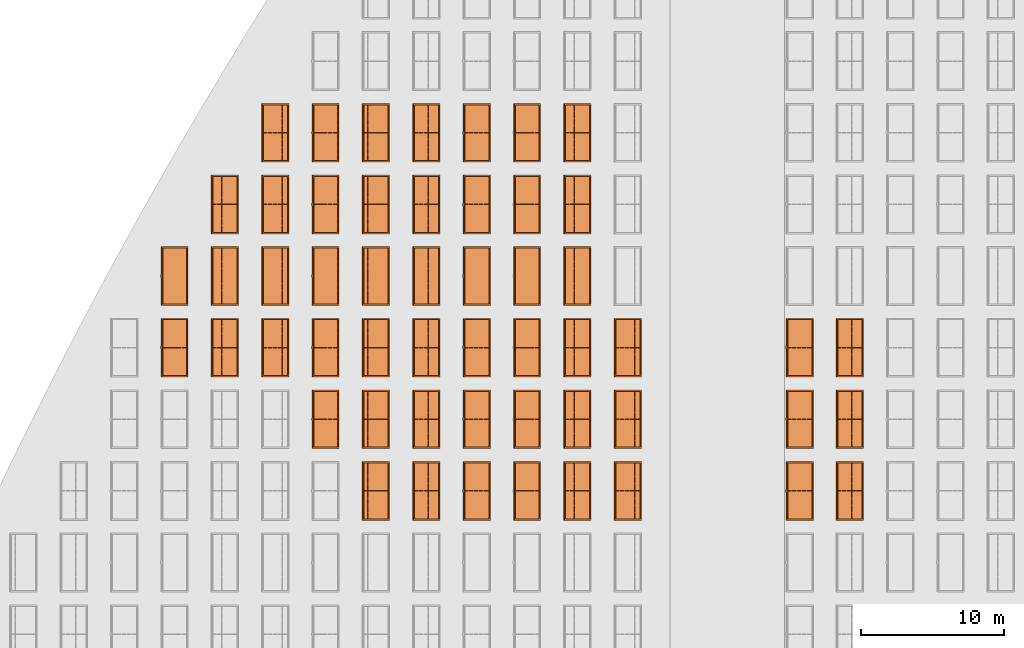
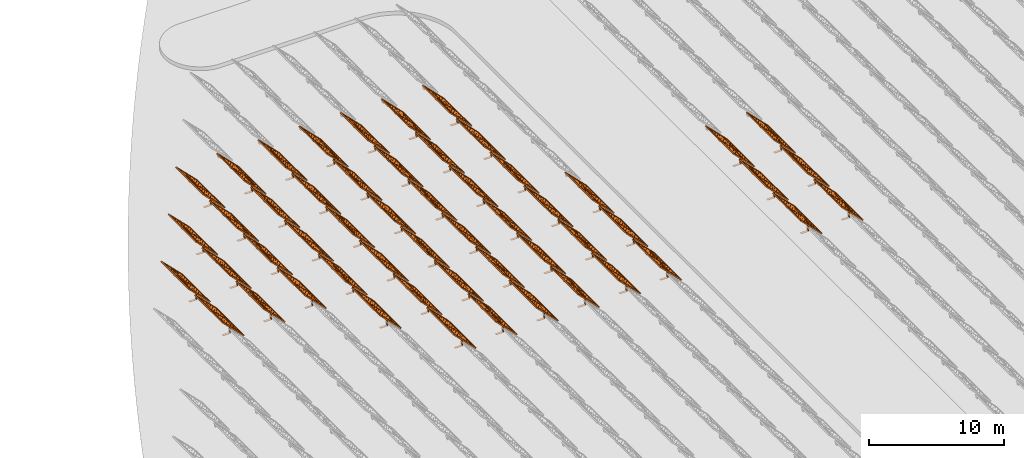
# One storey, part 29 of 39: 53 proxies.
"""IFC2X3 building model written with IfcOpenShell, lengths in millimetres."""

from ifc_helpers import new_model, entity, si_unit, converted_unit, derived_unit, direction, frame, frame_2d, origin, origin_2d_with_axis, place, context, subcontext, project, spatial, polyline, rectangle, outline, extrude, source, transform, mapped, material, material_list, element, save


model = new_model("IFC2X3")

# Units and contexts
model_context = context("Model", 3, precision=1e-06, world=origin(), true_north=direction((2.0, 6.12303176911189e-17, 1.0)))
context_of_model = context(None, 3, precision=1e-06, world=origin(), true_north=direction((2.0, 6.12303176911189e-17, 1.0)))
body_context = subcontext(model_context, "Body", "Model", "MODEL_VIEW")
ifc_project = project(units=[si_unit("LENGTHUNIT", "METRE", prefix="MILLI"), si_unit("AREAUNIT", "SQUARE_METRE", prefix="MILLI"), si_unit("VOLUMEUNIT", "CUBIC_METRE", prefix="MILLI"), converted_unit("PLANEANGLEUNIT", "DEGREE", entity("IfcRatioMeasure", 0.0174532925199433), si_unit("PLANEANGLEUNIT", "RADIAN"), dimensions=[0, 0, 0, 0, 0, 0, 0]), si_unit("MASSUNIT", "GRAM", prefix="KILO"), si_unit("TIMEUNIT", "SECOND"), si_unit("THERMODYNAMICTEMPERATUREUNIT", "KELVIN"), derived_unit("THERMALTRANSMITTANCEUNIT", [(si_unit("MASSUNIT", "GRAM", prefix="KILO"), 1), (si_unit("THERMODYNAMICTEMPERATUREUNIT", "KELVIN"), -1), (si_unit("TIMEUNIT", "SECOND"), -3)]), derived_unit("VOLUMETRICFLOWRATEUNIT", [(si_unit("LENGTHUNIT", "METRE"), 3), (si_unit("TIMEUNIT", "SECOND"), -1)])], contexts=[model_context, context_of_model])

# Site, building, storey
site_placement = place(None, origin())
site = spatial("IfcSite", under=ifc_project, at=site_placement, CompositionType="ELEMENT")
building_placement = place(site_placement, origin())
building = spatial("IfcBuilding", under=site, at=building_placement, CompositionType="ELEMENT")
storey_placement = place(building_placement, frame((0.0, 0.0, 4000.0)))
storey = spatial("IfcBuildingStorey", under=building, at=storey_placement, Name="Level 2", CompositionType="ELEMENT", Elevation=4000.0)

# Proxies
ifc_material_1 = material(Name="Stand-Steel")
ifc_material_2 = material(Name="Aluminium")
ifc_material_3 = material(Name="Glass")
ifc_material_list_1 = material_list([ifc_material_1, ifc_material_2, ifc_material_3])
shared_shape = source(origin(), body_context, "Body", "SweptSolid", [
    extrude(outline(polyline([(-629.526235435404, -220.0), (329.763117717702, -220.0), (329.763117717703, 410.0), (299.763117717703, 410.0), (299.763117717702, -190.0), (-629.526235435404, -190.0), (-629.526235435404, -220.0)])), frame((-190.00003127179, -100.0, 299.763117717707), z_axis=(0.0, 1.0, 0.0), x_axis=(0.0, 0.0, -1.0)), (0.0, 0.0, 1.0), 200.0),
    extrude(rectangle(XDim=20.0000000000001, YDim=200.0, at=frame_2d((0.0, -7.105427357601e-14), x_axis=(0.0, 1.0))), frame((-7.07109908365613, 0.0, 922.21828534124), z_axis=(-0.70710678118654, 0.0, 0.707106781186555), x_axis=(0.0, 1.0, 0.0)), (0.0, 0.0, 1.0), 2600.0),
    extrude(rectangle(XDim=24.9999999999997, YDim=24.9999999999999, at=frame_2d((2.87769807982841e-13, -9.50350909079134e-14), x_axis=(1.0, 0.0))), frame((-1449.56292018118, -1950.0, 2449.57494522722), z_axis=(0.0, 1.0, 0.0), x_axis=(-0.707106781186548, 0.0, -0.707106781186548)), (0.0, 0.0, 1.0), 3900.0),
    extrude(rectangle(XDim=24.9999999999999, YDim=25.0000000000001, at=origin_2d_with_axis()), frame((-1096.0095295879, -1950.0, 2096.02155463395), z_axis=(0.0, 1.0, 0.0), x_axis=(-0.707106781186542, 0.0, -0.707106781186553)), (0.0, 0.0, 1.0), 3900.0),
    extrude(rectangle(XDim=24.9999999999999, YDim=25.0000000000001, at=origin_2d_with_axis()), frame((-742.456138994631, -1950.0, 1742.46816404067), z_axis=(0.0, 1.0, 0.0), x_axis=(-0.707106781186542, 0.0, -0.707106781186553)), (0.0, 0.0, 1.0), 3900.0),
    extrude(rectangle(XDim=25.0, YDim=24.9999999999997, at=frame_2d((-7.19424519957101e-14, 1.19904086659517e-13), x_axis=(1.0, 0.0))), frame((-388.902748401358, -1950.0, 1388.9147734474), z_axis=(0.0, 1.0, 0.0), x_axis=(-0.707106781186545, 0.0, -0.70710678118655)), (0.0, 0.0, 1.0), 3900.0),
    extrude(rectangle(XDim=25.0000000000002, YDim=25.0, at=frame_2d((1.35891298214119e-13, 6.21724893790088e-15), x_axis=(0.0, 1.0))), frame((-35.3553703311048, 1500.0, 1035.35537033109), z_axis=(-0.707106781186544, 0.0, 0.707106781186551), x_axis=(0.0, 1.0, 0.0)), (0.0, 0.0, 1.0), 2440.0),
    extrude(rectangle(XDim=25.0000000000002, YDim=25.0, at=frame_2d((0.0, 1.77635683940025e-15), x_axis=(0.0, 1.0))), frame((-35.3553703311059, 1000.0, 1035.35537033109), z_axis=(-0.707106781186546, 0.0, 0.707106781186549), x_axis=(0.0, 1.0, 0.0)), (0.0, 0.0, 1.0), 2440.0),
    extrude(rectangle(XDim=25.0000000000002, YDim=25.0, at=frame_2d((0.0, 8.43769498715119e-14), x_axis=(0.0, 1.0))), frame((-26.5165355662756, 0.0, 1044.19420509593), z_axis=(-0.707106781186546, 0.0, 0.707106781186549), x_axis=(0.0, -1.0, 0.0)), (0.0, 0.0, 1.0), 2440.0),
    extrude(rectangle(XDim=25.0000000000002, YDim=25.0, at=frame_2d((0.0, 8.88178419700125e-16), x_axis=(0.0, 1.0))), frame((-35.3553703311065, 500.0, 1035.35537033109), z_axis=(-0.707106781186546, 0.0, 0.707106781186549), x_axis=(0.0, 1.0, 0.0)), (0.0, 0.0, 1.0), 2440.0),
    extrude(rectangle(XDim=25.0000000000002, YDim=25.0, at=frame_2d((0.0, 8.88178419700125e-16), x_axis=(0.0, 1.0))), frame((-35.3553703311086, -500.0, 1035.35537033109), z_axis=(-0.707106781186546, 0.0, 0.707106781186549), x_axis=(0.0, 1.0, 0.0)), (0.0, 0.0, 1.0), 2440.0),
    extrude(rectangle(XDim=25.0000000000002, YDim=25.0, at=frame_2d((0.0, 8.88178419700125e-16), x_axis=(0.0, 1.0))), frame((-35.3553703311095, -1000.0, 1035.35537033109), z_axis=(-0.707106781186546, 0.0, 0.707106781186549), x_axis=(0.0, 1.0, 0.0)), (0.0, 0.0, 1.0), 2440.0),
    extrude(rectangle(XDim=25.0000000000002, YDim=25.0, at=frame_2d((1.35891298214119e-13, 1.77635683940025e-15), x_axis=(0.0, 1.0))), frame((-35.3553703311107, -1500.0, 1035.35537033109), z_axis=(-0.707106781186546, 0.0, 0.707106781186549), x_axis=(0.0, 1.0, 0.0)), (0.0, 0.0, 1.0), 2440.0),
    extrude(rectangle(XDim=2400.0, YDim=11.9999999999994, at=frame_2d((-1.13686837721616e-13, 2.02948768901479e-13), x_axis=(1.0, 0.0))), frame((-883.883507754966, -1950.0, 1883.88350775495), z_axis=(0.0, 1.0, 0.0), x_axis=(0.707106781186546, 0.0, -0.707106781186549)), (0.0, 0.0, 1.0), 3900.0),
    extrude(outline(polyline([(-2050.0, -1300.0), (2050.0, -1300.0), (2050.0, 1300.0), (-2050.0, 1300.0), (-2050.0, -1300.0)]), holes=[polyline([(1950.0, -1200.0), (-1950.0, -1200.0), (-1950.0, 1200.0), (1950.0, 1200.0), (1950.0, -1200.0)])]), frame((-919.238846814293, 0.0, 1848.52816869563), z_axis=(0.707106781186554, 0.0, 0.707106781186541), x_axis=(0.0, 1.0, 0.0)), (0.0, 0.0, 1.0), 99.9999999999898),
])
proxy_1_placement = place(storey_placement, frame((-144385.32831183, 595144.680552408, 30.0)))
element("IfcBuildingElementProxy", 1, at=proxy_1_placement, inside=storey, material=ifc_material_list_1, Name="Solar Panel_4000X2500:Solar Panel_4000X2500", ObjectType="Solar Panel_4000X2500", CompositionType="ELEMENT", context=body_context, shape_type="MappedRepresentation", body=[
    mapped(shared_shape, transform((0.0, 0.0, 0.0), scale=1.0)),
])
ifc_material_list_2 = material_list([ifc_material_1, ifc_material_2, ifc_material_3])
proxy_2_placement = place(storey_placement, frame((-144385.32831183, 600144.680552408, 30.0)))
element("IfcBuildingElementProxy", 2, at=proxy_2_placement, inside=storey, material=ifc_material_list_2, Name="Solar Panel_4000X2500:Solar Panel_4000X2500", ObjectType="Solar Panel_4000X2500", CompositionType="ELEMENT", context=body_context, shape_type="MappedRepresentation", body=[
    mapped(shared_shape, transform((0.0, 0.0, 0.0), scale=1.0)),
])
ifc_material_list_3 = material_list([ifc_material_1, ifc_material_2, ifc_material_3])
proxy_3_placement = place(storey_placement, frame((-144385.32831183, 605144.680552408, 30.0)))
element("IfcBuildingElementProxy", 3, at=proxy_3_placement, inside=storey, material=ifc_material_list_3, Name="Solar Panel_4000X2500:Solar Panel_4000X2500", ObjectType="Solar Panel_4000X2500", CompositionType="ELEMENT", context=body_context, shape_type="MappedRepresentation", body=[
    mapped(shared_shape, transform((0.0, 0.0, 0.0), scale=1.0)),
])
ifc_material_list_4 = material_list([ifc_material_1, ifc_material_2, ifc_material_3])
proxy_4_placement = place(storey_placement, frame((-147885.32831183, 595144.680552408, 30.0)))
element("IfcBuildingElementProxy", 4, at=proxy_4_placement, inside=storey, material=ifc_material_list_4, Name="Solar Panel_4000X2500:Solar Panel_4000X2500", ObjectType="Solar Panel_4000X2500", CompositionType="ELEMENT", context=body_context, shape_type="MappedRepresentation", body=[
    mapped(shared_shape, transform((0.0, 0.0, 0.0), scale=1.0)),
])
ifc_material_list_5 = material_list([ifc_material_1, ifc_material_2, ifc_material_3])
proxy_5_placement = place(storey_placement, frame((-147885.32831183, 600144.680552408, 30.0)))
element("IfcBuildingElementProxy", 5, at=proxy_5_placement, inside=storey, material=ifc_material_list_5, Name="Solar Panel_4000X2500:Solar Panel_4000X2500", ObjectType="Solar Panel_4000X2500", CompositionType="ELEMENT", context=body_context, shape_type="MappedRepresentation", body=[
    mapped(shared_shape, transform((0.0, 0.0, 0.0), scale=1.0)),
])
ifc_material_list_6 = material_list([ifc_material_1, ifc_material_2, ifc_material_3])
proxy_6_placement = place(storey_placement, frame((-147885.32831183, 605144.680552408, 30.0)))
element("IfcBuildingElementProxy", 6, at=proxy_6_placement, inside=storey, material=ifc_material_list_6, Name="Solar Panel_4000X2500:Solar Panel_4000X2500", ObjectType="Solar Panel_4000X2500", CompositionType="ELEMENT", context=body_context, shape_type="MappedRepresentation", body=[
    mapped(shared_shape, transform((0.0, 0.0, 0.0), scale=1.0)),
])
ifc_material_list_7 = material_list([ifc_material_1, ifc_material_2, ifc_material_3])
proxy_7_placement = place(storey_placement, frame((-159885.32831183, 595144.680552408, 30.0)))
element("IfcBuildingElementProxy", 7, at=proxy_7_placement, inside=storey, material=ifc_material_list_7, Name="Solar Panel_4000X2500:Solar Panel_4000X2500", ObjectType="Solar Panel_4000X2500", CompositionType="ELEMENT", context=body_context, shape_type="MappedRepresentation", body=[
    mapped(shared_shape, transform((0.0, 0.0, 0.0), scale=1.0)),
])
ifc_material_list_8 = material_list([ifc_material_1, ifc_material_2, ifc_material_3])
proxy_8_placement = place(storey_placement, frame((-159885.32831183, 600144.680552408, 30.0)))
element("IfcBuildingElementProxy", 8, at=proxy_8_placement, inside=storey, material=ifc_material_list_8, Name="Solar Panel_4000X2500:Solar Panel_4000X2500", ObjectType="Solar Panel_4000X2500", CompositionType="ELEMENT", context=body_context, shape_type="MappedRepresentation", body=[
    mapped(shared_shape, transform((0.0, 0.0, 0.0), scale=1.0)),
])
ifc_material_list_9 = material_list([ifc_material_1, ifc_material_2, ifc_material_3])
proxy_9_placement = place(storey_placement, frame((-159885.32831183, 605144.680552408, 30.0)))
element("IfcBuildingElementProxy", 9, at=proxy_9_placement, inside=storey, material=ifc_material_list_9, Name="Solar Panel_4000X2500:Solar Panel_4000X2500", ObjectType="Solar Panel_4000X2500", CompositionType="ELEMENT", context=body_context, shape_type="MappedRepresentation", body=[
    mapped(shared_shape, transform((0.0, 0.0, 0.0), scale=1.0)),
])
ifc_material_list_10 = material_list([ifc_material_1, ifc_material_2, ifc_material_3])
proxy_10_placement = place(storey_placement, frame((-163400.32831183, 595144.680552408, 30.0)))
element("IfcBuildingElementProxy", 10, at=proxy_10_placement, inside=storey, material=ifc_material_list_10, Name="Solar Panel_4000X2500:Solar Panel_4000X2500", ObjectType="Solar Panel_4000X2500", CompositionType="ELEMENT", context=body_context, shape_type="MappedRepresentation", body=[
    mapped(shared_shape, transform((0.0, 0.0, 0.0), scale=1.0)),
])
ifc_material_list_11 = material_list([ifc_material_1, ifc_material_2, ifc_material_3])
proxy_11_placement = place(storey_placement, frame((-163400.32831183, 600144.680552408, 30.0)))
element("IfcBuildingElementProxy", 11, at=proxy_11_placement, inside=storey, material=ifc_material_list_11, Name="Solar Panel_4000X2500:Solar Panel_4000X2500", ObjectType="Solar Panel_4000X2500", CompositionType="ELEMENT", context=body_context, shape_type="MappedRepresentation", body=[
    mapped(shared_shape, transform((0.0, 0.0, 0.0), scale=1.0)),
])
ifc_material_list_12 = material_list([ifc_material_1, ifc_material_2, ifc_material_3])
proxy_12_placement = place(storey_placement, frame((-163400.32831183, 605144.680552408, 30.0)))
element("IfcBuildingElementProxy", 12, at=proxy_12_placement, inside=storey, material=ifc_material_list_12, Name="Solar Panel_4000X2500:Solar Panel_4000X2500", ObjectType="Solar Panel_4000X2500", CompositionType="ELEMENT", context=body_context, shape_type="MappedRepresentation", body=[
    mapped(shared_shape, transform((0.0, 0.0, 0.0), scale=1.0)),
])
ifc_material_list_13 = material_list([ifc_material_1, ifc_material_2, ifc_material_3])
proxy_13_placement = place(storey_placement, frame((-163400.32831183, 610144.680552408, 30.0)))
element("IfcBuildingElementProxy", 13, at=proxy_13_placement, inside=storey, material=ifc_material_list_13, Name="Solar Panel_4000X2500:Solar Panel_4000X2500", ObjectType="Solar Panel_4000X2500", CompositionType="ELEMENT", context=body_context, shape_type="MappedRepresentation", body=[
    mapped(shared_shape, transform((0.0, 0.0, 0.0), scale=1.0)),
])
ifc_material_list_14 = material_list([ifc_material_1, ifc_material_2, ifc_material_3])
proxy_14_placement = place(storey_placement, frame((-163400.32831183, 615144.680552408, 30.0)))
element("IfcBuildingElementProxy", 14, at=proxy_14_placement, inside=storey, material=ifc_material_list_14, Name="Solar Panel_4000X2500:Solar Panel_4000X2500", ObjectType="Solar Panel_4000X2500", CompositionType="ELEMENT", context=body_context, shape_type="MappedRepresentation", body=[
    mapped(shared_shape, transform((0.0, 0.0, 0.0), scale=1.0)),
])
ifc_material_list_15 = material_list([ifc_material_1, ifc_material_2, ifc_material_3])
proxy_15_placement = place(storey_placement, frame((-163400.32831183, 620144.680552408, 30.0)))
element("IfcBuildingElementProxy", 15, at=proxy_15_placement, inside=storey, material=ifc_material_list_15, Name="Solar Panel_4000X2500:Solar Panel_4000X2500", ObjectType="Solar Panel_4000X2500", CompositionType="ELEMENT", context=body_context, shape_type="MappedRepresentation", body=[
    mapped(shared_shape, transform((0.0, 0.0, 0.0), scale=1.0)),
])
ifc_material_list_16 = material_list([ifc_material_1, ifc_material_2, ifc_material_3])
proxy_16_placement = place(storey_placement, frame((-166915.32831183, 595144.680552408, 30.0)))
element("IfcBuildingElementProxy", 16, at=proxy_16_placement, inside=storey, material=ifc_material_list_16, Name="Solar Panel_4000X2500:Solar Panel_4000X2500", ObjectType="Solar Panel_4000X2500", CompositionType="ELEMENT", context=body_context, shape_type="MappedRepresentation", body=[
    mapped(shared_shape, transform((0.0, 0.0, 0.0), scale=1.0)),
])
ifc_material_list_17 = material_list([ifc_material_1, ifc_material_2, ifc_material_3])
proxy_17_placement = place(storey_placement, frame((-166915.32831183, 600144.680552408, 30.0)))
element("IfcBuildingElementProxy", 17, at=proxy_17_placement, inside=storey, material=ifc_material_list_17, Name="Solar Panel_4000X2500:Solar Panel_4000X2500", ObjectType="Solar Panel_4000X2500", CompositionType="ELEMENT", context=body_context, shape_type="MappedRepresentation", body=[
    mapped(shared_shape, transform((0.0, 0.0, 0.0), scale=1.0)),
])
ifc_material_list_18 = material_list([ifc_material_1, ifc_material_2, ifc_material_3])
proxy_18_placement = place(storey_placement, frame((-166915.32831183, 605144.680552408, 30.0)))
element("IfcBuildingElementProxy", 18, at=proxy_18_placement, inside=storey, material=ifc_material_list_18, Name="Solar Panel_4000X2500:Solar Panel_4000X2500", ObjectType="Solar Panel_4000X2500", CompositionType="ELEMENT", context=body_context, shape_type="MappedRepresentation", body=[
    mapped(shared_shape, transform((0.0, 0.0, 0.0), scale=1.0)),
])
ifc_material_list_19 = material_list([ifc_material_1, ifc_material_2, ifc_material_3])
proxy_19_placement = place(storey_placement, frame((-166915.32831183, 610144.680552408, 30.0)))
element("IfcBuildingElementProxy", 19, at=proxy_19_placement, inside=storey, material=ifc_material_list_19, Name="Solar Panel_4000X2500:Solar Panel_4000X2500", ObjectType="Solar Panel_4000X2500", CompositionType="ELEMENT", context=body_context, shape_type="MappedRepresentation", body=[
    mapped(shared_shape, transform((0.0, 0.0, 0.0), scale=1.0)),
])
ifc_material_list_20 = material_list([ifc_material_1, ifc_material_2, ifc_material_3])
proxy_20_placement = place(storey_placement, frame((-166915.32831183, 615144.680552408, 30.0)))
element("IfcBuildingElementProxy", 20, at=proxy_20_placement, inside=storey, material=ifc_material_list_20, Name="Solar Panel_4000X2500:Solar Panel_4000X2500", ObjectType="Solar Panel_4000X2500", CompositionType="ELEMENT", context=body_context, shape_type="MappedRepresentation", body=[
    mapped(shared_shape, transform((0.0, 0.0, 0.0), scale=1.0)),
])
ifc_material_list_21 = material_list([ifc_material_1, ifc_material_2, ifc_material_3])
proxy_21_placement = place(storey_placement, frame((-166915.32831183, 620144.680552408, 30.0)))
element("IfcBuildingElementProxy", 21, at=proxy_21_placement, inside=storey, material=ifc_material_list_21, Name="Solar Panel_4000X2500:Solar Panel_4000X2500", ObjectType="Solar Panel_4000X2500", CompositionType="ELEMENT", context=body_context, shape_type="MappedRepresentation", body=[
    mapped(shared_shape, transform((0.0, 0.0, 0.0), scale=1.0)),
])
ifc_material_list_22 = material_list([ifc_material_1, ifc_material_2, ifc_material_3])
proxy_22_placement = place(storey_placement, frame((-170430.32831183, 595144.680552408, 30.0)))
element("IfcBuildingElementProxy", 22, at=proxy_22_placement, inside=storey, material=ifc_material_list_22, Name="Solar Panel_4000X2500:Solar Panel_4000X2500", ObjectType="Solar Panel_4000X2500", CompositionType="ELEMENT", context=body_context, shape_type="MappedRepresentation", body=[
    mapped(shared_shape, transform((0.0, 0.0, 0.0), scale=1.0)),
])
ifc_material_list_23 = material_list([ifc_material_1, ifc_material_2, ifc_material_3])
proxy_23_placement = place(storey_placement, frame((-170430.32831183, 600144.680552408, 30.0)))
element("IfcBuildingElementProxy", 23, at=proxy_23_placement, inside=storey, material=ifc_material_list_23, Name="Solar Panel_4000X2500:Solar Panel_4000X2500", ObjectType="Solar Panel_4000X2500", CompositionType="ELEMENT", context=body_context, shape_type="MappedRepresentation", body=[
    mapped(shared_shape, transform((0.0, 0.0, 0.0), scale=1.0)),
])
ifc_material_list_24 = material_list([ifc_material_1, ifc_material_2, ifc_material_3])
proxy_24_placement = place(storey_placement, frame((-170430.32831183, 605144.680552408, 30.0)))
element("IfcBuildingElementProxy", 24, at=proxy_24_placement, inside=storey, material=ifc_material_list_24, Name="Solar Panel_4000X2500:Solar Panel_4000X2500", ObjectType="Solar Panel_4000X2500", CompositionType="ELEMENT", context=body_context, shape_type="MappedRepresentation", body=[
    mapped(shared_shape, transform((0.0, 0.0, 0.0), scale=1.0)),
])
ifc_material_list_25 = material_list([ifc_material_1, ifc_material_2, ifc_material_3])
proxy_25_placement = place(storey_placement, frame((-170430.32831183, 610144.680552408, 30.0)))
element("IfcBuildingElementProxy", 25, at=proxy_25_placement, inside=storey, material=ifc_material_list_25, Name="Solar Panel_4000X2500:Solar Panel_4000X2500", ObjectType="Solar Panel_4000X2500", CompositionType="ELEMENT", context=body_context, shape_type="MappedRepresentation", body=[
    mapped(shared_shape, transform((0.0, 0.0, 0.0), scale=1.0)),
])
ifc_material_list_26 = material_list([ifc_material_1, ifc_material_2, ifc_material_3])
proxy_26_placement = place(storey_placement, frame((-170430.32831183, 615144.680552408, 30.0)))
element("IfcBuildingElementProxy", 26, at=proxy_26_placement, inside=storey, material=ifc_material_list_26, Name="Solar Panel_4000X2500:Solar Panel_4000X2500", ObjectType="Solar Panel_4000X2500", CompositionType="ELEMENT", context=body_context, shape_type="MappedRepresentation", body=[
    mapped(shared_shape, transform((0.0, 0.0, 0.0), scale=1.0)),
])
ifc_material_list_27 = material_list([ifc_material_1, ifc_material_2, ifc_material_3])
proxy_27_placement = place(storey_placement, frame((-170430.32831183, 620144.680552408, 30.0)))
element("IfcBuildingElementProxy", 27, at=proxy_27_placement, inside=storey, material=ifc_material_list_27, Name="Solar Panel_4000X2500:Solar Panel_4000X2500", ObjectType="Solar Panel_4000X2500", CompositionType="ELEMENT", context=body_context, shape_type="MappedRepresentation", body=[
    mapped(shared_shape, transform((0.0, 0.0, 0.0), scale=1.0)),
])
ifc_material_list_28 = material_list([ifc_material_1, ifc_material_2, ifc_material_3])
proxy_28_placement = place(storey_placement, frame((-173945.32831183, 595144.680552408, 30.0)))
element("IfcBuildingElementProxy", 28, at=proxy_28_placement, inside=storey, material=ifc_material_list_28, Name="Solar Panel_4000X2500:Solar Panel_4000X2500", ObjectType="Solar Panel_4000X2500", CompositionType="ELEMENT", context=body_context, shape_type="MappedRepresentation", body=[
    mapped(shared_shape, transform((0.0, 0.0, 0.0), scale=1.0)),
])
ifc_material_list_29 = material_list([ifc_material_1, ifc_material_2, ifc_material_3])
proxy_29_placement = place(storey_placement, frame((-173945.32831183, 600144.680552408, 30.0)))
element("IfcBuildingElementProxy", 29, at=proxy_29_placement, inside=storey, material=ifc_material_list_29, Name="Solar Panel_4000X2500:Solar Panel_4000X2500", ObjectType="Solar Panel_4000X2500", CompositionType="ELEMENT", context=body_context, shape_type="MappedRepresentation", body=[
    mapped(shared_shape, transform((0.0, 0.0, 0.0), scale=1.0)),
])
ifc_material_list_30 = material_list([ifc_material_1, ifc_material_2, ifc_material_3])
proxy_30_placement = place(storey_placement, frame((-173945.32831183, 605144.680552408, 30.0)))
element("IfcBuildingElementProxy", 30, at=proxy_30_placement, inside=storey, material=ifc_material_list_30, Name="Solar Panel_4000X2500:Solar Panel_4000X2500", ObjectType="Solar Panel_4000X2500", CompositionType="ELEMENT", context=body_context, shape_type="MappedRepresentation", body=[
    mapped(shared_shape, transform((0.0, 0.0, 0.0), scale=1.0)),
])
ifc_material_list_31 = material_list([ifc_material_1, ifc_material_2, ifc_material_3])
proxy_31_placement = place(storey_placement, frame((-173945.32831183, 610144.680552408, 30.0)))
element("IfcBuildingElementProxy", 31, at=proxy_31_placement, inside=storey, material=ifc_material_list_31, Name="Solar Panel_4000X2500:Solar Panel_4000X2500", ObjectType="Solar Panel_4000X2500", CompositionType="ELEMENT", context=body_context, shape_type="MappedRepresentation", body=[
    mapped(shared_shape, transform((0.0, 0.0, 0.0), scale=1.0)),
])
ifc_material_list_32 = material_list([ifc_material_1, ifc_material_2, ifc_material_3])
proxy_32_placement = place(storey_placement, frame((-173945.32831183, 615144.680552408, 30.0)))
element("IfcBuildingElementProxy", 32, at=proxy_32_placement, inside=storey, material=ifc_material_list_32, Name="Solar Panel_4000X2500:Solar Panel_4000X2500", ObjectType="Solar Panel_4000X2500", CompositionType="ELEMENT", context=body_context, shape_type="MappedRepresentation", body=[
    mapped(shared_shape, transform((0.0, 0.0, 0.0), scale=1.0)),
])
ifc_material_list_33 = material_list([ifc_material_1, ifc_material_2, ifc_material_3])
proxy_33_placement = place(storey_placement, frame((-173945.32831183, 620144.680552408, 30.0)))
element("IfcBuildingElementProxy", 33, at=proxy_33_placement, inside=storey, material=ifc_material_list_33, Name="Solar Panel_4000X2500:Solar Panel_4000X2500", ObjectType="Solar Panel_4000X2500", CompositionType="ELEMENT", context=body_context, shape_type="MappedRepresentation", body=[
    mapped(shared_shape, transform((0.0, 0.0, 0.0), scale=1.0)),
])
ifc_material_list_34 = material_list([ifc_material_1, ifc_material_2, ifc_material_3])
proxy_34_placement = place(storey_placement, frame((-177460.32831183, 595144.680552408, 30.0)))
element("IfcBuildingElementProxy", 34, at=proxy_34_placement, inside=storey, material=ifc_material_list_34, Name="Solar Panel_4000X2500:Solar Panel_4000X2500", ObjectType="Solar Panel_4000X2500", CompositionType="ELEMENT", context=body_context, shape_type="MappedRepresentation", body=[
    mapped(shared_shape, transform((0.0, 0.0, 0.0), scale=1.0)),
])
ifc_material_list_35 = material_list([ifc_material_1, ifc_material_2, ifc_material_3])
proxy_35_placement = place(storey_placement, frame((-177460.32831183, 600144.680552408, 30.0)))
element("IfcBuildingElementProxy", 35, at=proxy_35_placement, inside=storey, material=ifc_material_list_35, Name="Solar Panel_4000X2500:Solar Panel_4000X2500", ObjectType="Solar Panel_4000X2500", CompositionType="ELEMENT", context=body_context, shape_type="MappedRepresentation", body=[
    mapped(shared_shape, transform((0.0, 0.0, 0.0), scale=1.0)),
])
ifc_material_list_36 = material_list([ifc_material_1, ifc_material_2, ifc_material_3])
proxy_36_placement = place(storey_placement, frame((-177460.32831183, 605144.680552408, 30.0)))
element("IfcBuildingElementProxy", 36, at=proxy_36_placement, inside=storey, material=ifc_material_list_36, Name="Solar Panel_4000X2500:Solar Panel_4000X2500", ObjectType="Solar Panel_4000X2500", CompositionType="ELEMENT", context=body_context, shape_type="MappedRepresentation", body=[
    mapped(shared_shape, transform((0.0, 0.0, 0.0), scale=1.0)),
])
ifc_material_list_37 = material_list([ifc_material_1, ifc_material_2, ifc_material_3])
proxy_37_placement = place(storey_placement, frame((-177460.32831183, 610144.680552408, 30.0)))
element("IfcBuildingElementProxy", 37, at=proxy_37_placement, inside=storey, material=ifc_material_list_37, Name="Solar Panel_4000X2500:Solar Panel_4000X2500", ObjectType="Solar Panel_4000X2500", CompositionType="ELEMENT", context=body_context, shape_type="MappedRepresentation", body=[
    mapped(shared_shape, transform((0.0, 0.0, 0.0), scale=1.0)),
])
ifc_material_list_38 = material_list([ifc_material_1, ifc_material_2, ifc_material_3])
proxy_38_placement = place(storey_placement, frame((-177460.32831183, 615144.680552408, 30.0)))
element("IfcBuildingElementProxy", 38, at=proxy_38_placement, inside=storey, material=ifc_material_list_38, Name="Solar Panel_4000X2500:Solar Panel_4000X2500", ObjectType="Solar Panel_4000X2500", CompositionType="ELEMENT", context=body_context, shape_type="MappedRepresentation", body=[
    mapped(shared_shape, transform((0.0, 0.0, 0.0), scale=1.0)),
])
ifc_material_list_39 = material_list([ifc_material_1, ifc_material_2, ifc_material_3])
proxy_39_placement = place(storey_placement, frame((-177460.32831183, 620144.680552408, 30.0)))
element("IfcBuildingElementProxy", 39, at=proxy_39_placement, inside=storey, material=ifc_material_list_39, Name="Solar Panel_4000X2500:Solar Panel_4000X2500", ObjectType="Solar Panel_4000X2500", CompositionType="ELEMENT", context=body_context, shape_type="MappedRepresentation", body=[
    mapped(shared_shape, transform((0.0, 0.0, 0.0), scale=1.0)),
])
ifc_material_list_40 = material_list([ifc_material_1, ifc_material_2, ifc_material_3])
proxy_40_placement = place(storey_placement, frame((-180975.32831183, 600144.680552408, 30.0)))
element("IfcBuildingElementProxy", 40, at=proxy_40_placement, inside=storey, material=ifc_material_list_40, Name="Solar Panel_4000X2500:Solar Panel_4000X2500", ObjectType="Solar Panel_4000X2500", CompositionType="ELEMENT", context=body_context, shape_type="MappedRepresentation", body=[
    mapped(shared_shape, transform((0.0, 0.0, 0.0), scale=1.0)),
])
ifc_material_list_41 = material_list([ifc_material_1, ifc_material_2, ifc_material_3])
proxy_41_placement = place(storey_placement, frame((-180975.32831183, 605144.680552408, 30.0)))
element("IfcBuildingElementProxy", 41, at=proxy_41_placement, inside=storey, material=ifc_material_list_41, Name="Solar Panel_4000X2500:Solar Panel_4000X2500", ObjectType="Solar Panel_4000X2500", CompositionType="ELEMENT", context=body_context, shape_type="MappedRepresentation", body=[
    mapped(shared_shape, transform((0.0, 0.0, 0.0), scale=1.0)),
])
ifc_material_list_42 = material_list([ifc_material_1, ifc_material_2, ifc_material_3])
proxy_42_placement = place(storey_placement, frame((-180975.32831183, 610144.680552408, 30.0)))
element("IfcBuildingElementProxy", 42, at=proxy_42_placement, inside=storey, material=ifc_material_list_42, Name="Solar Panel_4000X2500:Solar Panel_4000X2500", ObjectType="Solar Panel_4000X2500", CompositionType="ELEMENT", context=body_context, shape_type="MappedRepresentation", body=[
    mapped(shared_shape, transform((0.0, 0.0, 0.0), scale=1.0)),
])
ifc_material_list_43 = material_list([ifc_material_1, ifc_material_2, ifc_material_3])
proxy_43_placement = place(storey_placement, frame((-180975.32831183, 615144.680552408, 30.0)))
element("IfcBuildingElementProxy", 43, at=proxy_43_placement, inside=storey, material=ifc_material_list_43, Name="Solar Panel_4000X2500:Solar Panel_4000X2500", ObjectType="Solar Panel_4000X2500", CompositionType="ELEMENT", context=body_context, shape_type="MappedRepresentation", body=[
    mapped(shared_shape, transform((0.0, 0.0, 0.0), scale=1.0)),
])
ifc_material_list_44 = material_list([ifc_material_1, ifc_material_2, ifc_material_3])
proxy_44_placement = place(storey_placement, frame((-184490.32831183, 605144.680552408, 30.0)))
element("IfcBuildingElementProxy", 44, at=proxy_44_placement, inside=storey, material=ifc_material_list_44, Name="Solar Panel_4000X2500:Solar Panel_4000X2500", ObjectType="Solar Panel_4000X2500", CompositionType="ELEMENT", context=body_context, shape_type="MappedRepresentation", body=[
    mapped(shared_shape, transform((0.0, 0.0, 0.0), scale=1.0)),
])
ifc_material_list_45 = material_list([ifc_material_1, ifc_material_2, ifc_material_3])
proxy_45_placement = place(storey_placement, frame((-184490.32831183, 610144.680552408, 30.0)))
element("IfcBuildingElementProxy", 45, at=proxy_45_placement, inside=storey, material=ifc_material_list_45, Name="Solar Panel_4000X2500:Solar Panel_4000X2500", ObjectType="Solar Panel_4000X2500", CompositionType="ELEMENT", context=body_context, shape_type="MappedRepresentation", body=[
    mapped(shared_shape, transform((0.0, 0.0, 0.0), scale=1.0)),
])
ifc_material_list_46 = material_list([ifc_material_1, ifc_material_2, ifc_material_3])
proxy_46_placement = place(storey_placement, frame((-184490.32831183, 615144.680552408, 30.0)))
element("IfcBuildingElementProxy", 46, at=proxy_46_placement, inside=storey, material=ifc_material_list_46, Name="Solar Panel_4000X2500:Solar Panel_4000X2500", ObjectType="Solar Panel_4000X2500", CompositionType="ELEMENT", context=body_context, shape_type="MappedRepresentation", body=[
    mapped(shared_shape, transform((0.0, 0.0, 0.0), scale=1.0)),
])
ifc_material_list_47 = material_list([ifc_material_1, ifc_material_2, ifc_material_3])
proxy_47_placement = place(storey_placement, frame((-188005.32831183, 605144.680552408, 30.0)))
element("IfcBuildingElementProxy", 47, at=proxy_47_placement, inside=storey, material=ifc_material_list_47, Name="Solar Panel_4000X2500:Solar Panel_4000X2500", ObjectType="Solar Panel_4000X2500", CompositionType="ELEMENT", context=body_context, shape_type="MappedRepresentation", body=[
    mapped(shared_shape, transform((0.0, 0.0, 0.0), scale=1.0)),
])
ifc_material_list_48 = material_list([ifc_material_1, ifc_material_2, ifc_material_3])
proxy_48_placement = place(storey_placement, frame((-188005.32831183, 610144.680552408, 30.0)))
element("IfcBuildingElementProxy", 48, at=proxy_48_placement, inside=storey, material=ifc_material_list_48, Name="Solar Panel_4000X2500:Solar Panel_4000X2500", ObjectType="Solar Panel_4000X2500", CompositionType="ELEMENT", context=body_context, shape_type="MappedRepresentation", body=[
    mapped(shared_shape, transform((0.0, 0.0, 0.0), scale=1.0)),
])
ifc_material_list_49 = material_list([ifc_material_1, ifc_material_2, ifc_material_3])
proxy_49_placement = place(storey_placement, frame((-191520.32831183, 605144.680552408, 30.0)))
element("IfcBuildingElementProxy", 49, at=proxy_49_placement, inside=storey, material=ifc_material_list_49, Name="Solar Panel_4000X2500:Solar Panel_4000X2500", ObjectType="Solar Panel_4000X2500", CompositionType="ELEMENT", context=body_context, shape_type="MappedRepresentation", body=[
    mapped(shared_shape, transform((0.0, 0.0, 0.0), scale=1.0)),
])
ifc_material_list_50 = material_list([ifc_material_1, ifc_material_2, ifc_material_3])
proxy_50_placement = place(storey_placement, frame((-184490.32831183, 620144.680552408, 30.0)))
element("IfcBuildingElementProxy", 50, at=proxy_50_placement, inside=storey, material=ifc_material_list_50, Name="Solar Panel_4000X2500:Solar Panel_4000X2500", ObjectType="Solar Panel_4000X2500", CompositionType="ELEMENT", context=body_context, shape_type="MappedRepresentation", body=[
    mapped(shared_shape, transform((0.0, 0.0, 0.0), scale=1.0)),
])
ifc_material_list_51 = material_list([ifc_material_1, ifc_material_2, ifc_material_3])
proxy_51_placement = place(storey_placement, frame((-188005.32831183, 615144.680552408, 30.0)))
element("IfcBuildingElementProxy", 51, at=proxy_51_placement, inside=storey, material=ifc_material_list_51, Name="Solar Panel_4000X2500:Solar Panel_4000X2500", ObjectType="Solar Panel_4000X2500", CompositionType="ELEMENT", context=body_context, shape_type="MappedRepresentation", body=[
    mapped(shared_shape, transform((0.0, 0.0, 0.0), scale=1.0)),
])
ifc_material_list_52 = material_list([ifc_material_1, ifc_material_2, ifc_material_3])
proxy_52_placement = place(storey_placement, frame((-191520.32831183, 610144.680552408, 30.0)))
element("IfcBuildingElementProxy", 52, at=proxy_52_placement, inside=storey, material=ifc_material_list_52, Name="Solar Panel_4000X2500:Solar Panel_4000X2500", ObjectType="Solar Panel_4000X2500", CompositionType="ELEMENT", context=body_context, shape_type="MappedRepresentation", body=[
    mapped(shared_shape, transform((0.0, 0.0, 0.0), scale=1.0)),
])
ifc_material_list_53 = material_list([ifc_material_1, ifc_material_2, ifc_material_3])
proxy_53_placement = place(storey_placement, frame((-180975.32831183, 620144.680552408, 30.0)))
element("IfcBuildingElementProxy", 53, at=proxy_53_placement, inside=storey, material=ifc_material_list_53, Name="Solar Panel_4000X2500:Solar Panel_4000X2500", ObjectType="Solar Panel_4000X2500", CompositionType="ELEMENT", context=body_context, shape_type="MappedRepresentation", body=[
    mapped(shared_shape, transform((0.0, 0.0, 0.0), scale=1.0)),
])

save(model, "model.ifc")
